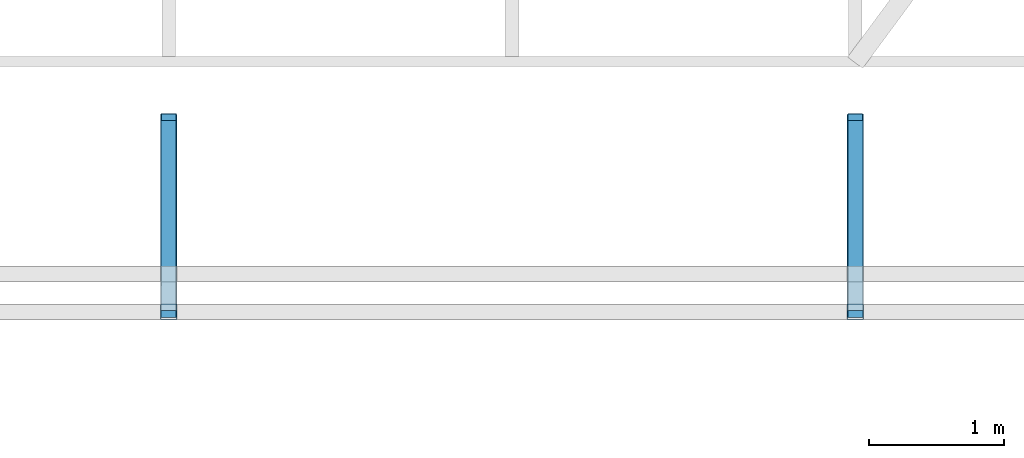
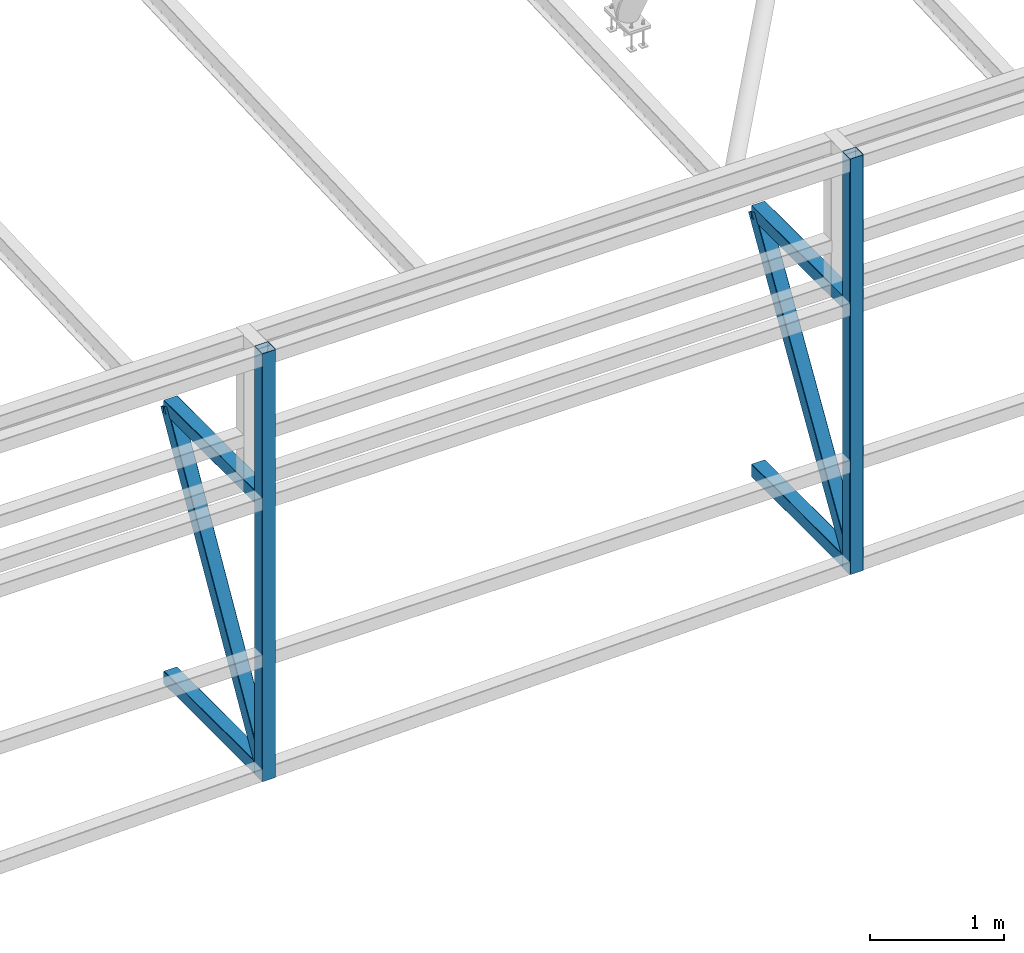
# One storey, part 109 of 215: 6 beams, 2 members, 8 elements without a shape of their own.
"""IFC2X3 building model written with IfcOpenShell, lengths in millimetres."""

from ifc_helpers import new_model, si_unit, frame, origin_with_axes, origin_2d_with_axis, place, context, subcontext, project, spatial, hollow_rectangle, extrude, material, type_object, element, aggregate, save


model = new_model("IFC2X3")

# Units and contexts
model_context = context("Model", 3, precision=1e-05, world=origin_with_axes())
body_context = subcontext(model_context, "Body", "Model", "MODEL_VIEW")
ifc_project = project(units=[si_unit("LENGTHUNIT", "METRE", prefix="MILLI"), si_unit("AREAUNIT", "SQUARE_METRE"), si_unit("VOLUMEUNIT", "CUBIC_METRE"), si_unit("MASSUNIT", "GRAM", prefix="KILO"), si_unit("TIMEUNIT", "SECOND"), si_unit("PLANEANGLEUNIT", "RADIAN"), si_unit("SOLIDANGLEUNIT", "STERADIAN"), si_unit("THERMODYNAMICTEMPERATUREUNIT", "DEGREE_CELSIUS"), si_unit("LUMINOUSINTENSITYUNIT", "LUMEN")], contexts=[model_context])

# Site, building, storey
site_placement = place(None, origin_with_axes())
site = spatial("IfcSite", under=ifc_project, at=site_placement, CompositionType="ELEMENT")
building_placement = place(site_placement, origin_with_axes())
building = spatial("IfcBuilding", under=site, at=building_placement, Name="Undefined", CompositionType="ELEMENT")
storey_placement = place(building_placement, origin_with_axes())
storey = spatial("IfcBuildingStorey", under=building, at=storey_placement, Name="Undefined", CompositionType="ELEMENT", Elevation=0.0)

# Assembly, beam
assembly_1_placement = place(storey_placement, origin_with_axes())
assembly_1 = element("IfcElementAssembly", 1, at=assembly_1_placement, inside=storey, Name="Steel Assembly", AssemblyPlace="NOTDEFINED", PredefinedType="RIGID_FRAME")
ifc_material = material(Name="STEEL/S275JR")
beam_type = type_object("IfcBeamType", PredefinedType="NOTDEFINED")
beam_1_placement = place(assembly_1_placement, frame((119365.008170935, 34554.8983288035, 485.780977702814), z_axis=(0.0, 0.0, 1.0), x_axis=(-6.93889390390723e-18, -1.0, -3.46944695195361e-18)))
beam_1 = element("IfcBeam", 2, at=beam_1_placement, type_object=beam_type, material=ifc_material, Name="LISSE", context=body_context, shape_type="SweptSolid", body=[
    extrude(hollow_rectangle(XDim=120.0, YDim=120.0, WallThickness=4.0, InnerFilletRadius=4.0, OuterFilletRadius=8.0, at=origin_2d_with_axis()), frame((1404.9181154153, 1.48751491493898e-19, -2.84217094304217e-14), z_axis=(-1.0, 0.0, 0.0), x_axis=(-6.93889390390723e-18, -1.0, -3.46944695195361e-18)), (0.0, 0.0, 1.0), 1404.9),
])
aggregate(assembly_1, [beam_1])

assembly_2_placement = place(storey_placement, origin_with_axes())
assembly_2 = element("IfcElementAssembly", 3, at=assembly_2_placement, inside=storey, Name="Steel Assembly", AssemblyPlace="NOTDEFINED", PredefinedType="RIGID_FRAME")
beam_2_placement = place(assembly_2_placement, frame((124445.007678642, 34554.9080492185, 599.572471448764), z_axis=(0.0, 0.0, 1.0), x_axis=(-6.93889390390723e-18, -1.0, -3.46944695195361e-18)))
beam_2 = element("IfcBeam", 4, at=beam_2_placement, type_object=beam_type, material=ifc_material, Name="LISSE", context=body_context, shape_type="SweptSolid", body=[
    extrude(hollow_rectangle(XDim=120.0, YDim=120.0, WallThickness=4.0, InnerFilletRadius=4.0, OuterFilletRadius=8.0, at=origin_2d_with_axis()), frame((1404.9181154153, 1.48751491493898e-19, -2.84217094304217e-14), z_axis=(-1.0, 0.0, 0.0), x_axis=(-6.93889390390723e-18, -1.0, -3.46944695195361e-18)), (0.0, 0.0, 1.0), 1404.9),
])
aggregate(assembly_2, [beam_2])

assembly_3_placement = place(storey_placement, origin_with_axes())
assembly_3 = element("IfcElementAssembly", 5, at=assembly_3_placement, inside=storey, Name="Steel Assembly", AssemblyPlace="NOTDEFINED", PredefinedType="RIGID_FRAME")
beam_3_placement = place(assembly_3_placement, frame((119365.009578888, 34554.8949227021, 2963.99602185051), z_axis=(0.0, 0.0, -1.0), x_axis=(-4.41999996209638e-07, -0.999999999999642, 7.22000000069896e-07)))
beam_3 = element("IfcBeam", 6, at=beam_3_placement, type_object=beam_type, material=ifc_material, Name="LISSE", context=body_context, shape_type="SweptSolid", body=[
    extrude(hollow_rectangle(XDim=120.0, YDim=120.0, WallThickness=4.0, InnerFilletRadius=4.0, OuterFilletRadius=8.0, at=origin_2d_with_axis()), frame((1404.89231313232, 5.39143026605448e-20, -1.48748759570922e-19), z_axis=(-1.0, 0.0, 0.0), x_axis=(-6.93889390390723e-18, -1.0, -3.46944695195361e-18)), (0.0, 0.0, 1.0), 1404.9),
])
aggregate(assembly_3, [beam_3])

assembly_4_placement = place(storey_placement, origin_with_axes())
assembly_4 = element("IfcElementAssembly", 7, at=assembly_4_placement, inside=storey, Name="Steel Assembly", AssemblyPlace="NOTDEFINED", PredefinedType="RIGID_FRAME")
beam_4_placement = place(assembly_4_placement, frame((124445.009086576, 34554.9046432634, 2963.99602185051), z_axis=(0.0, 0.0, -1.0), x_axis=(-4.41999996209638e-07, -0.999999999999642, 7.22000000069896e-07)))
beam_4 = element("IfcBeam", 8, at=beam_4_placement, type_object=beam_type, material=ifc_material, Name="LISSE", context=body_context, shape_type="SweptSolid", body=[
    extrude(hollow_rectangle(XDim=120.0, YDim=120.0, WallThickness=4.0, InnerFilletRadius=4.0, OuterFilletRadius=8.0, at=origin_2d_with_axis()), frame((1404.89231313232, 5.39143026605448e-20, -1.48748759570922e-19), z_axis=(-1.0, 0.0, 0.0), x_axis=(-6.93889390390723e-18, -1.0, -3.46944695195361e-18)), (0.0, 0.0, 1.0), 1404.9),
])
aggregate(assembly_4, [beam_4])

assembly_5_placement = place(storey_placement, origin_with_axes())
assembly_5 = element("IfcElementAssembly", 9, at=assembly_5_placement, inside=storey, Name="Steel Assembly", AssemblyPlace="NOTDEFINED", PredefinedType="RIGID_FRAME")
beam_5_placement = place(assembly_5_placement, frame((119365.009074428, 33139.9359134363, 4339.19097157212), z_axis=(1.91399999311775e-06, -0.999999999998168, 0.0), x_axis=(0.0, 0.0, -1.0)))
beam_5 = element("IfcBeam", 10, at=beam_5_placement, type_object=beam_type, material=ifc_material, Name="LISSE", context=body_context, shape_type="SweptSolid", body=[
    extrude(hollow_rectangle(XDim=120.0, YDim=120.0, WallThickness=4.0, InnerFilletRadius=4.0, OuterFilletRadius=8.0, at=origin_2d_with_axis()), frame((3912.06820813406, 0.0, 0.0), z_axis=(-1.0, 0.0, 0.0), x_axis=(-6.93889390390723e-18, -1.0, -3.46944695195361e-18)), (0.0, 0.0, 1.0), 3912.1),
])
aggregate(assembly_5, [beam_5])

assembly_6_placement = place(storey_placement, origin_with_axes())
assembly_6 = element("IfcElementAssembly", 11, at=assembly_6_placement, inside=storey, Name="Steel Assembly", AssemblyPlace="NOTDEFINED", PredefinedType="RIGID_FRAME")
beam_6_placement = place(assembly_6_placement, frame((124445.008582122, 33139.9456365068, 4339.19097162822), z_axis=(1.91399999311775e-06, -0.999999999998168, 0.0), x_axis=(0.0, 0.0, -1.0)))
beam_6 = element("IfcBeam", 12, at=beam_6_placement, type_object=beam_type, material=ifc_material, Name="LISSE", context=body_context, shape_type="SweptSolid", body=[
    extrude(hollow_rectangle(XDim=120.0, YDim=120.0, WallThickness=4.0, InnerFilletRadius=4.0, OuterFilletRadius=8.0, at=origin_2d_with_axis()), frame((3798.27583581538, 0.0, 0.0), z_axis=(-1.0, 0.0, 0.0), x_axis=(-6.93889390390723e-18, -1.0, -3.46944695195361e-18)), (0.0, 0.0, 1.0), 3798.3),
])
aggregate(assembly_6, [beam_6])

# Assembly, member
assembly_7_placement = place(storey_placement, origin_with_axes())
assembly_7 = element("IfcElementAssembly", 13, at=assembly_7_placement, inside=storey, Name="Steel Assembly", AssemblyPlace="NOTDEFINED", PredefinedType="RIGID_FRAME")
member_type = type_object("IfcMemberType", PredefinedType="NOTDEFINED")
member_1_placement = place(assembly_7_placement, frame((119365.004356599, 33149.9662716842, 546.236325755976), z_axis=(-0.00119496899986089, -0.864622344896625, 0.50242091193993), x_axis=(4.99899999965703e-06, 0.502421265212378, 0.864622965365484)))
member_1 = element("IfcMember", 14, at=member_1_placement, type_object=member_type, material=ifc_material, Name="LISSE", context=body_context, shape_type="SweptSolid", body=[
    extrude(hollow_rectangle(XDim=120.0, YDim=120.0, WallThickness=4.0, InnerFilletRadius=4.0, OuterFilletRadius=8.0, at=origin_2d_with_axis()), frame((2796.31676819383, 0.0, 3.1045352601942e-13), z_axis=(-1.0, 0.0, 0.0), x_axis=(-6.93889390390723e-18, -1.0, -3.46944695195361e-18)), (0.0, 0.0, 1.0), 2796.3),
])
aggregate(assembly_7, [member_1])

assembly_8_placement = place(storey_placement, origin_with_axes())
assembly_8 = element("IfcElementAssembly", 15, at=assembly_8_placement, inside=storey, Name="Steel Assembly", AssemblyPlace="NOTDEFINED", PredefinedType="RIGID_FRAME")
member_2_placement = place(assembly_8_placement, frame((124445.012263001, 33149.9900953823, 659.57246394876), z_axis=(-0.00132535300005436, -0.853831948039593, 0.520547066024139), x_axis=(-1.17800000083277e-06, 0.520547524205561, 0.853832697337173)))
member_2 = element("IfcMember", 16, at=member_2_placement, type_object=member_type, material=ifc_material, Name="LISSE", context=body_context, shape_type="SweptSolid", body=[
    extrude(hollow_rectangle(XDim=120.0, YDim=120.0, WallThickness=4.0, InnerFilletRadius=4.0, OuterFilletRadius=8.0, at=origin_2d_with_axis()), frame((2698.91697109803, -1.45513299940382e-11, 7.1261376260402e-12), z_axis=(-1.0, 0.0, 0.0), x_axis=(-6.93889390390723e-18, -1.0, -3.46944695195361e-18)), (0.0, 0.0, 1.0), 2698.9),
])
aggregate(assembly_8, [member_2])

save(model, "model.ifc")
